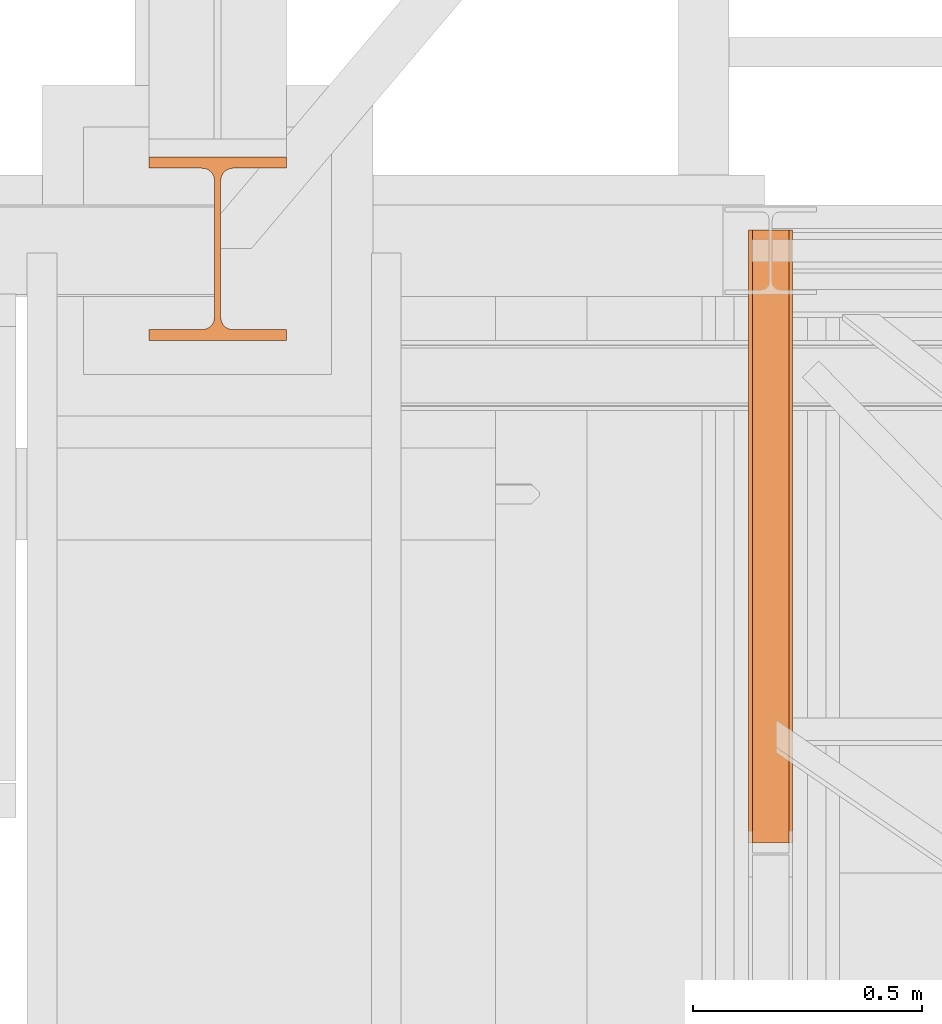
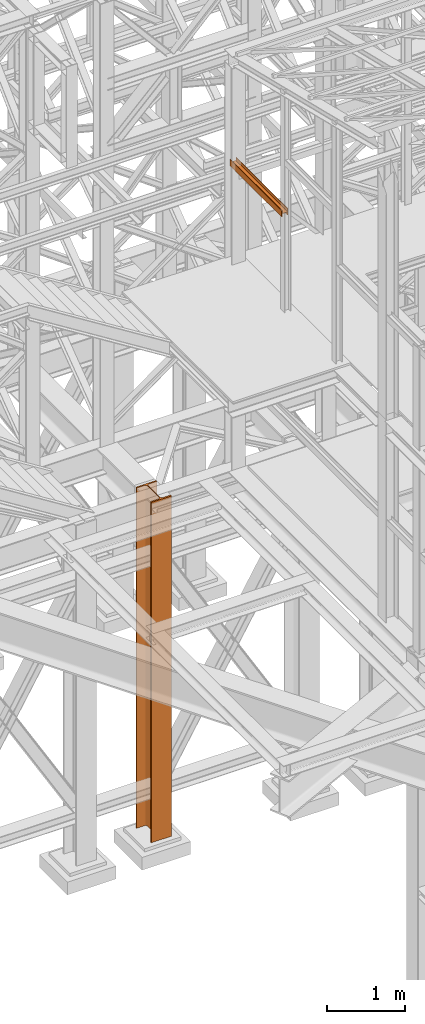
# One storey, part 31 of 208: 3 proxies.
"""IFC2X3 building model written with IfcOpenShell, lengths in millimetres."""

from ifc_helpers import new_model, entity, si_unit, converted_unit, frame, origin, origin_with_axes, place, context, subcontext, project, spatial, faceted_brep, element, save


model = new_model("IFC2X3")

# Units and contexts
model_context = context("Model", 3, precision=1e-05, world=origin())
plan_context = context("Plan", 3, precision=1e-05, world=origin())
body_context = subcontext(model_context, "Body", "Model", "MODEL_VIEW")
ifc_project = project(units=[si_unit("LENGTHUNIT", "METRE", prefix="MILLI"), converted_unit("PLANEANGLEUNIT", "DEGREE", entity("IfcPlaneAngleMeasure", 0.0174532925199433), si_unit("PLANEANGLEUNIT", "RADIAN"), dimensions=[0, 0, 0, 0, 0, 0, 0]), si_unit("AREAUNIT", "SQUARE_METRE"), si_unit("VOLUMEUNIT", "CUBIC_METRE")], contexts=[model_context, plan_context])

# Building, storey
building_placement = place(None, origin())
building = spatial("IfcBuilding", under=ifc_project, at=building_placement, CompositionType="COMPLEX")
storey_placement = place(building_placement, origin_with_axes())
storey = spatial("IfcBuildingStorey", under=building, at=storey_placement, Name="Geschoss", CompositionType="ELEMENT")

# Proxies
proxy_1_placement = place(storey_placement, frame((1150.254968528656, -18552.57438994535, 9977.249663113742), z_axis=(0.0, 0.0, 1.0), x_axis=(1.0, 0.0, 0.0)))
element("IfcBuildingElementProxy", 1, at=proxy_1_placement, inside=storey, context=body_context, shape_type="Brep", body=[
    faceted_brep([(8.009999999999991, 0.00999999999839929, 0.01000000000021828), (0.009999999999990905, 0.00999999999839929, 0.01000000000021828), (0.009999999999990905, 0.00999999999839929, 100.0100000000002), (8.009999999999991, 0.00999999999839929, 100.0100000000002), (8.009999999999991, 0.00999999999839929, 52.51000000000022), (88.00999999999999, 0.00999999999839929, 52.51000000000022), (88.00999999999999, 0.00999999999839929, 100.0100000000002), (96.00999999999999, 0.00999999999839929, 100.0100000000002), (96.00999999999999, 0.00999999999839929, 0.01000000000021828), (88.00999999999999, 0.00999999999839929, 0.01000000000021828), (88.00999999999999, 0.00999999999839929, 47.51000000000022), (8.009999999999991, 0.00999999999839929, 47.51000000000022), (0.009999999999990905, 0.00999999999839929, 0.01000000000021828), (8.009999999999991, 0.00999999999839929, 0.01000000000021828), (8.009999999999991, 1334.847202244597, 0.01000684652535711), (0.009999999999990905, 1334.847202244597, 0.01000684652535711), (0.009999999999990905, 0.00999999999839929, 100.0100000000002), (0.009999999999990905, 0.00999999999839929, 0.01000000000021828), (0.009999999999990905, 1334.847202244597, 0.01000684652535711), (0.009999999999990905, 1334.847202244597, 100.0100068465254), (8.009999999999991, 0.00999999999839929, 100.0100000000002), (0.009999999999990905, 0.00999999999839929, 100.0100000000002), (0.009999999999990905, 1334.847202244597, 100.0100068465254), (8.009999999999991, 1334.847202244597, 100.0100068465254), (8.009999999999991, 0.00999999999839929, 52.51000000000022), (8.009999999999991, 0.00999999999839929, 100.0100000000002), (8.009999999999991, 1334.847202244597, 100.0100068465254), (8.009999999999991, 1334.847202244597, 52.51000684652536), (88.00999999999999, 0.00999999999839929, 52.51000000000022), (8.009999999999991, 0.00999999999839929, 52.51000000000022), (8.009999999999991, 1334.847202244597, 52.51000684652536), (88.00999999999999, 1334.847202244597, 52.51000684652536), (88.00999999999999, 0.00999999999839929, 100.0100000000002), (88.00999999999999, 0.00999999999839929, 52.51000000000022), (88.00999999999999, 1334.847202244597, 52.51000684652536), (88.00999999999999, 1334.847202244597, 100.0100068465254), (96.00999999999999, 0.00999999999839929, 100.0100000000002), (88.00999999999999, 0.00999999999839929, 100.0100000000002), (88.00999999999999, 1334.847202244597, 100.0100068465254), (96.00999999999999, 1334.847202244597, 100.0100068465254), (96.00999999999999, 0.00999999999839929, 0.01000000000021828), (96.00999999999999, 0.00999999999839929, 100.0100000000002), (96.00999999999999, 1334.847202244597, 100.0100068465254), (96.00999999999999, 1334.847202244597, 0.01000684652535711), (88.00999999999999, 0.00999999999839929, 0.01000000000021828), (96.00999999999999, 0.00999999999839929, 0.01000000000021828), (96.00999999999999, 1334.847202244597, 0.01000684652535711), (88.00999999999999, 1334.847202244597, 0.01000684652535711), (88.00999999999999, 0.00999999999839929, 47.51000000000022), (88.00999999999999, 0.00999999999839929, 0.01000000000021828), (88.00999999999999, 1334.847202244597, 0.01000684652535711), (88.00999999999999, 1334.847202244597, 47.51000684652536), (8.009999999999991, 0.00999999999839929, 47.51000000000022), (88.00999999999999, 0.00999999999839929, 47.51000000000022), (88.00999999999999, 1334.847202244597, 47.51000684652536), (8.009999999999991, 1334.847202244597, 47.51000684652536), (8.009999999999991, 0.00999999999839929, 0.01000000000021828), (8.009999999999991, 0.00999999999839929, 47.51000000000022), (8.009999999999991, 1334.847202244597, 47.51000684652536), (8.009999999999991, 1334.847202244597, 0.01000684652535711), (8.009999999999991, 1334.847202244597, 0.01000684652535711), (8.009999999999991, 1334.847202244597, 47.51000684652536), (88.00999999999999, 1334.847202244597, 47.51000684652536), (88.00999999999999, 1334.847202244597, 0.01000684652535711), (96.00999999999999, 1334.847202244597, 0.01000684652535711), (96.00999999999999, 1334.847202244597, 100.0100068465254), (88.00999999999999, 1334.847202244597, 100.0100068465254), (88.00999999999999, 1334.847202244597, 52.51000684652536), (8.009999999999991, 1334.847202244597, 52.51000684652536), (8.009999999999991, 1334.847202244597, 100.0100068465254), (0.009999999999990905, 1334.847202244597, 100.0100068465254), (0.009999999999990905, 1334.847202244597, 0.01000684652535711)], [[[0, 1, 2, 3, 4, 5, 6, 7, 8, 9, 10, 11]], [[12, 13, 14, 15]], [[16, 17, 18, 19]], [[20, 21, 22, 23]], [[24, 25, 26, 27]], [[28, 29, 30, 31]], [[32, 33, 34, 35]], [[36, 37, 38, 39]], [[40, 41, 42, 43]], [[44, 45, 46, 47]], [[48, 49, 50, 51]], [[52, 53, 54, 55]], [[56, 57, 58, 59]], [[60, 61, 62, 63, 64, 65, 66, 67, 68, 69, 70, 71]]], orient=[[False], [False], [False], [False], [False], [False], [False], [False], [False], [False], [False], [False], [False], [False]]),
])
proxy_2_placement = place(storey_placement, frame((1150.254968528656, -18552.57438994535, 9977.249663113742), z_axis=(0.0, 0.0, 1.0), x_axis=(1.0, 0.0, 0.0)))
element("IfcBuildingElementProxy", 2, at=proxy_2_placement, inside=storey, context=body_context, shape_type="Brep", body=[
    faceted_brep([(8.009999999999991, 0.00999999999839929, 0.01000000000021828), (0.009999999999990905, 0.00999999999839929, 0.01000000000021828), (0.009999999999990905, 0.00999999999839929, 100.0100000000002), (8.009999999999991, 0.00999999999839929, 100.0100000000002), (8.009999999999991, 0.00999999999839929, 52.51000000000022), (88.00999999999999, 0.00999999999839929, 52.51000000000022), (88.00999999999999, 0.00999999999839929, 100.0100000000002), (96.00999999999999, 0.00999999999839929, 100.0100000000002), (96.00999999999999, 0.00999999999839929, 0.01000000000021828), (88.00999999999999, 0.00999999999839929, 0.01000000000021828), (88.00999999999999, 0.00999999999839929, 47.51000000000022), (8.009999999999991, 0.00999999999839929, 47.51000000000022), (0.009999999999990905, 0.00999999999839929, 0.01000000000021828), (8.009999999999991, 0.00999999999839929, 0.01000000000021828), (8.009999999999991, 1334.847202244597, 0.01000684652535711), (0.009999999999990905, 1334.847202244597, 0.01000684652535711), (0.009999999999990905, 0.00999999999839929, 100.0100000000002), (0.009999999999990905, 0.00999999999839929, 0.01000000000021828), (0.009999999999990905, 1334.847202244597, 0.01000684652535711), (0.009999999999990905, 1334.847202244597, 100.0100068465254), (8.009999999999991, 0.00999999999839929, 100.0100000000002), (0.009999999999990905, 0.00999999999839929, 100.0100000000002), (0.009999999999990905, 1334.847202244597, 100.0100068465254), (8.009999999999991, 1334.847202244597, 100.0100068465254), (8.009999999999991, 0.00999999999839929, 52.51000000000022), (8.009999999999991, 0.00999999999839929, 100.0100000000002), (8.009999999999991, 1334.847202244597, 100.0100068465254), (8.009999999999991, 1334.847202244597, 52.51000684652536), (88.00999999999999, 0.00999999999839929, 52.51000000000022), (8.009999999999991, 0.00999999999839929, 52.51000000000022), (8.009999999999991, 1334.847202244597, 52.51000684652536), (88.00999999999999, 1334.847202244597, 52.51000684652536), (88.00999999999999, 0.00999999999839929, 100.0100000000002), (88.00999999999999, 0.00999999999839929, 52.51000000000022), (88.00999999999999, 1334.847202244597, 52.51000684652536), (88.00999999999999, 1334.847202244597, 100.0100068465254), (96.00999999999999, 0.00999999999839929, 100.0100000000002), (88.00999999999999, 0.00999999999839929, 100.0100000000002), (88.00999999999999, 1334.847202244597, 100.0100068465254), (96.00999999999999, 1334.847202244597, 100.0100068465254), (96.00999999999999, 0.00999999999839929, 0.01000000000021828), (96.00999999999999, 0.00999999999839929, 100.0100000000002), (96.00999999999999, 1334.847202244597, 100.0100068465254), (96.00999999999999, 1334.847202244597, 0.01000684652535711), (88.00999999999999, 0.00999999999839929, 0.01000000000021828), (96.00999999999999, 0.00999999999839929, 0.01000000000021828), (96.00999999999999, 1334.847202244597, 0.01000684652535711), (88.00999999999999, 1334.847202244597, 0.01000684652535711), (88.00999999999999, 0.00999999999839929, 47.51000000000022), (88.00999999999999, 0.00999999999839929, 0.01000000000021828), (88.00999999999999, 1334.847202244597, 0.01000684652535711), (88.00999999999999, 1334.847202244597, 47.51000684652536), (8.009999999999991, 0.00999999999839929, 47.51000000000022), (88.00999999999999, 0.00999999999839929, 47.51000000000022), (88.00999999999999, 1334.847202244597, 47.51000684652536), (8.009999999999991, 1334.847202244597, 47.51000684652536), (8.009999999999991, 0.00999999999839929, 0.01000000000021828), (8.009999999999991, 0.00999999999839929, 47.51000000000022), (8.009999999999991, 1334.847202244597, 47.51000684652536), (8.009999999999991, 1334.847202244597, 0.01000684652535711), (8.009999999999991, 1334.847202244597, 0.01000684652535711), (8.009999999999991, 1334.847202244597, 47.51000684652536), (88.00999999999999, 1334.847202244597, 47.51000684652536), (88.00999999999999, 1334.847202244597, 0.01000684652535711), (96.00999999999999, 1334.847202244597, 0.01000684652535711), (96.00999999999999, 1334.847202244597, 100.0100068465254), (88.00999999999999, 1334.847202244597, 100.0100068465254), (88.00999999999999, 1334.847202244597, 52.51000684652536), (8.009999999999991, 1334.847202244597, 52.51000684652536), (8.009999999999991, 1334.847202244597, 100.0100068465254), (0.009999999999990905, 1334.847202244597, 100.0100068465254), (0.009999999999990905, 1334.847202244597, 0.01000684652535711)], [[[0, 1, 2, 3, 4, 5, 6, 7, 8, 9, 10, 11]], [[12, 13, 14, 15]], [[16, 17, 18, 19]], [[20, 21, 22, 23]], [[24, 25, 26, 27]], [[28, 29, 30, 31]], [[32, 33, 34, 35]], [[36, 37, 38, 39]], [[40, 41, 42, 43]], [[44, 45, 46, 47]], [[48, 49, 50, 51]], [[52, 53, 54, 55]], [[56, 57, 58, 59]], [[60, 61, 62, 63, 64, 65, 66, 67, 68, 69, 70, 71]]], orient=[[False], [False], [False], [False], [False], [False], [False], [False], [False], [False], [False], [False], [False], [False]]),
])
proxy_3_placement = place(storey_placement, frame((-156.7450314713294, -17458.57439531565, -65.01000000000022), z_axis=(0.0, 0.0, 1.0), x_axis=(1.0, 0.0, 0.0)))
element("IfcBuildingElementProxy", 3, at=proxy_3_placement, inside=storey, Name="3D Element", context=body_context, shape_type="Brep", body=[
    faceted_brep([(0.009999999999990905, 400.0099999999984, 5350.010005364416), (300.01, 400.0099999999984, 5350.010005364416), (300.01, 376.0099999999984, 5350.010005364416), (183.76, 376.0099999999984, 5350.010005364416), (175.4165694541391, 374.6884339422577, 5350.010005364416), (167.8898249341985, 370.8534254633996, 5350.010005364416), (161.9165745365979, 364.8801750657985, 5350.010005364416), (157.9269689743871, 356.3774142355105, 5350.010005364416), (156.76, 349.0099999999984, 5350.010005364416), (156.76, 51.0099999999984, 5350.010005364416), (158.0815660577403, 42.66656945413706, 5350.010005364416), (161.9165745365979, 35.13982493419462, 5350.010005364416), (167.8898249341985, 29.16657453659718, 5350.010005364416), (175.4165694541391, 25.33156605773911, 5350.010005364416), (183.76, 24.0099999999984, 5350.010005364416), (300.01, 24.0099999999984, 5350.010005364416), (300.01, 0.00999999999839929, 5350.010005364416), (0.009999999999990905, 0.00999999999839929, 5350.010005364416), (0.009999999999990905, 24.0099999999984, 5350.010005364416), (116.26, 24.0099999999984, 5350.010005364416), (124.6034305458604, 25.33156605773911, 5350.010005364416), (132.1301750658015, 29.16657453659718, 5350.010005364416), (138.1034254634017, 35.13982493419462, 5350.010005364416), (141.9384339422597, 42.66656945413706, 5350.010005364416), (143.26, 51.0099999999984, 5350.010005364416), (143.26, 347.9786887785667, 5350.010005364416), (141.9384339422597, 357.3534305458597, 5350.010005364416), (138.1034254634021, 364.8801750657985, 5350.010005364416), (132.1301750658015, 370.8534254633996, 5350.010005364416), (124.6034305458604, 374.6884339422577, 5350.010005364416), (115.0308095164803, 376.0099999999984, 5350.010005364416), (0.009999999999990905, 376.0099999999984, 5350.010005364416), (300.01, 400.0099999999984, 5350.010005364416), (0.009999999999990905, 400.0099999999984, 5350.010005364416), (0.009999999999990905, 400.0099999999984, 0.01000000000021828), (300.01, 400.0099999999984, 0.01000000000021828), (300.01, 376.0099999999984, 5350.010005364416), (300.01, 400.0099999999984, 5350.010005364416), (300.01, 400.0099999999984, 0.01000000000021828), (300.01, 376.0099999999984, 0.01000000000021828), (183.76, 376.0099999999984, 5350.010005364416), (300.01, 376.0099999999984, 5350.010005364416), (300.01, 376.0099999999984, 0.01000000000021828), (183.76, 376.0099999999984, 0.01000000000021828), (175.4165694541391, 374.6884339422577, 5350.010005364416), (183.76, 376.0099999999984, 5350.010005364416), (183.76, 376.0099999999984, 0.01000000000021828), (175.4165694541391, 374.6884339422577, 0.01000000000021828), (167.8898249341985, 370.8534254633996, 5350.010005364416), (175.4165694541391, 374.6884339422577, 5350.010005364416), (175.4165694541391, 374.6884339422577, 0.01000000000021828), (167.8898249341985, 370.8534254633996, 0.01000000000021828), (161.9165745365979, 364.8801750657985, 5350.010005364416), (167.8898249341985, 370.8534254633996, 5350.010005364416), (167.8898249341985, 370.8534254633996, 0.01000000000021828), (161.9165745365979, 364.8801750657985, 0.01000000000021828), (157.9269689743871, 356.3774142355105, 5350.010005364416), (161.9165745365979, 364.8801750657985, 5350.010005364416), (161.9165745365979, 364.8801750657985, 0.01000000000021828), (157.9269689743871, 356.3774142355105, 0.01000000000021828), (156.76, 349.0099999999984, 5350.010005364416), (157.9269689743871, 356.3774142355105, 5350.010005364416), (157.9269689743871, 356.3774142355105, 0.01000000000021828), (156.76, 349.0099999999984, 0.01000000000021828), (156.76, 51.0099999999984, 5350.010005364416), (156.76, 349.0099999999984, 5350.010005364416), (156.76, 349.0099999999984, 0.01000000000021828), (156.76, 51.0099999999984, 0.01000000000021828), (158.0815660577403, 42.66656945413706, 5350.010005364416), (156.76, 51.0099999999984, 5350.010005364416), (156.76, 51.0099999999984, 0.01000000000021828), (158.0815660577403, 42.66656945413706, 0.01000000000021828), (161.9165745365979, 35.13982493419462, 5350.010005364416), (158.0815660577403, 42.66656945413706, 5350.010005364416), (158.0815660577403, 42.66656945413706, 0.01000000000021828), (161.9165745365979, 35.13982493419462, 0.01000000000021828), (167.8898249341985, 29.16657453659718, 5350.010005364416), (161.9165745365979, 35.13982493419462, 5350.010005364416), (161.9165745365979, 35.13982493419462, 0.01000000000021828), (167.8898249341985, 29.16657453659718, 0.01000000000021828), (175.4165694541391, 25.33156605773911, 5350.010005364416), (167.8898249341985, 29.16657453659718, 5350.010005364416), (167.8898249341985, 29.16657453659718, 0.01000000000021828), (175.4165694541391, 25.33156605773911, 0.01000000000021828), (183.76, 24.0099999999984, 5350.010005364416), (175.4165694541391, 25.33156605773911, 5350.010005364416), (175.4165694541391, 25.33156605773911, 0.01000000000021828), (183.76, 24.0099999999984, 0.01000000000021828), (300.01, 24.0099999999984, 5350.010005364416), (183.76, 24.0099999999984, 5350.010005364416), (183.76, 24.0099999999984, 0.01000000000021828), (300.01, 24.0099999999984, 0.01000000000021828), (300.01, 0.00999999999839929, 5350.010005364416), (300.01, 24.0099999999984, 5350.010005364416), (300.01, 24.0099999999984, 0.01000000000021828), (300.01, 0.00999999999839929, 0.01000000000021828), (0.009999999999990905, 0.00999999999839929, 5350.010005364416), (300.01, 0.00999999999839929, 5350.010005364416), (300.01, 0.00999999999839929, 0.01000000000021828), (0.009999999999990905, 0.00999999999839929, 0.01000000000021828), (0.009999999999990905, 24.0099999999984, 5350.010005364416), (0.009999999999990905, 0.00999999999839929, 5350.010005364416), (0.009999999999990905, 0.00999999999839929, 0.01000000000021828), (0.009999999999990905, 24.0099999999984, 0.01000000000021828), (116.26, 24.0099999999984, 5350.010005364416), (0.009999999999990905, 24.0099999999984, 5350.010005364416), (0.009999999999990905, 24.0099999999984, 0.01000000000021828), (116.26, 24.0099999999984, 0.01000000000021828), (124.6034305458604, 25.33156605773911, 5350.010005364416), (116.26, 24.0099999999984, 5350.010005364416), (116.26, 24.0099999999984, 0.01000000000021828), (124.6034305458604, 25.33156605773911, 0.01000000000021828), (132.1301750658015, 29.16657453659718, 5350.010005364416), (124.6034305458604, 25.33156605773911, 5350.010005364416), (124.6034305458604, 25.33156605773911, 0.01000000000021828), (132.1301750658015, 29.16657453659718, 0.01000000000021828), (138.1034254634017, 35.13982493419462, 5350.010005364416), (132.1301750658015, 29.16657453659718, 5350.010005364416), (132.1301750658015, 29.16657453659718, 0.01000000000021828), (138.1034254634017, 35.13982493419462, 0.01000000000021828), (141.9384339422597, 42.66656945413706, 5350.010005364416), (138.1034254634017, 35.13982493419462, 5350.010005364416), (138.1034254634017, 35.13982493419462, 0.01000000000021828), (141.9384339422597, 42.66656945413706, 0.01000000000021828), (143.26, 51.0099999999984, 5350.010005364416), (141.9384339422597, 42.66656945413706, 5350.010005364416), (141.9384339422597, 42.66656945413706, 0.01000000000021828), (143.26, 51.0099999999984, 0.01000000000021828), (143.26, 347.9786887785667, 5350.010005364416), (143.26, 51.0099999999984, 5350.010005364416), (143.26, 51.0099999999984, 0.01000000000021828), (143.26, 347.9786887785667, 0.01000000000021828), (141.9384339422597, 357.3534305458597, 5350.010005364416), (143.26, 347.9786887785667, 5350.010005364416), (143.26, 347.9786887785667, 0.01000000000021828), (141.9384339422597, 357.3534305458597, 0.01000000000021828), (138.1034254634021, 364.8801750657985, 5350.010005364416), (141.9384339422597, 357.3534305458597, 5350.010005364416), (141.9384339422597, 357.3534305458597, 0.01000000000021828), (138.1034254634021, 364.8801750657985, 0.01000000000021828), (132.1301750658015, 370.8534254633996, 5350.010005364416), (138.1034254634021, 364.8801750657985, 5350.010005364416), (138.1034254634021, 364.8801750657985, 0.01000000000021828), (132.1301750658015, 370.8534254633996, 0.01000000000021828), (124.6034305458604, 374.6884339422577, 5350.010005364416), (132.1301750658015, 370.8534254633996, 5350.010005364416), (132.1301750658015, 370.8534254633996, 0.01000000000021828), (124.6034305458604, 374.6884339422577, 0.01000000000021828), (115.0308095164803, 376.0099999999984, 5350.010005364416), (124.6034305458604, 374.6884339422577, 5350.010005364416), (124.6034305458604, 374.6884339422577, 0.01000000000021828), (115.0308095164803, 376.0099999999984, 0.01000000000021828), (0.009999999999990905, 376.0099999999984, 5350.010005364416), (115.0308095164803, 376.0099999999984, 5350.010005364416), (115.0308095164803, 376.0099999999984, 0.01000000000021828), (0.009999999999990905, 376.0099999999984, 0.01000000000021828), (0.009999999999990905, 400.0099999999984, 5350.010005364416), (0.009999999999990905, 376.0099999999984, 5350.010005364416), (0.009999999999990905, 376.0099999999984, 0.01000000000021828), (0.009999999999990905, 400.0099999999984, 0.01000000000021828), (0.009999999999990905, 400.0099999999984, 0.01000000000021828), (0.009999999999990905, 376.0099999999984, 0.01000000000021828), (115.0308095164803, 376.0099999999984, 0.01000000000021828), (124.6034305458604, 374.6884339422577, 0.01000000000021828), (132.1301750658015, 370.8534254633996, 0.01000000000021828), (138.1034254634021, 364.8801750657985, 0.01000000000021828), (141.9384339422597, 357.3534305458597, 0.01000000000021828), (143.26, 347.9786887785667, 0.01000000000021828), (143.26, 51.0099999999984, 0.01000000000021828), (141.9384339422597, 42.66656945413706, 0.01000000000021828), (138.1034254634017, 35.13982493419462, 0.01000000000021828), (132.1301750658015, 29.16657453659718, 0.01000000000021828), (124.6034305458604, 25.33156605773911, 0.01000000000021828), (116.26, 24.0099999999984, 0.01000000000021828), (0.009999999999990905, 24.0099999999984, 0.01000000000021828), (0.009999999999990905, 0.00999999999839929, 0.01000000000021828), (300.01, 0.00999999999839929, 0.01000000000021828), (300.01, 24.0099999999984, 0.01000000000021828), (183.76, 24.0099999999984, 0.01000000000021828), (175.4165694541391, 25.33156605773911, 0.01000000000021828), (167.8898249341985, 29.16657453659718, 0.01000000000021828), (161.9165745365979, 35.13982493419462, 0.01000000000021828), (158.0815660577403, 42.66656945413706, 0.01000000000021828), (156.76, 51.0099999999984, 0.01000000000021828), (156.76, 349.0099999999984, 0.01000000000021828), (157.9269689743871, 356.3774142355105, 0.01000000000021828), (161.9165745365979, 364.8801750657985, 0.01000000000021828), (167.8898249341985, 370.8534254633996, 0.01000000000021828), (175.4165694541391, 374.6884339422577, 0.01000000000021828), (183.76, 376.0099999999984, 0.01000000000021828), (300.01, 376.0099999999984, 0.01000000000021828), (300.01, 400.0099999999984, 0.01000000000021828)], [[[0, 1, 2, 3, 4, 5, 6, 7, 8, 9, 10, 11, 12, 13, 14, 15, 16, 17, 18, 19, 20, 21, 22, 23, 24, 25, 26, 27, 28, 29, 30, 31]], [[32, 33, 34, 35]], [[36, 37, 38, 39]], [[40, 41, 42, 43]], [[44, 45, 46, 47]], [[48, 49, 50, 51]], [[52, 53, 54, 55]], [[56, 57, 58, 59]], [[60, 61, 62, 63]], [[64, 65, 66, 67]], [[68, 69, 70, 71]], [[72, 73, 74, 75]], [[76, 77, 78, 79]], [[80, 81, 82, 83]], [[84, 85, 86, 87]], [[88, 89, 90, 91]], [[92, 93, 94, 95]], [[96, 97, 98, 99]], [[100, 101, 102, 103]], [[104, 105, 106, 107]], [[108, 109, 110, 111]], [[112, 113, 114, 115]], [[116, 117, 118, 119]], [[120, 121, 122, 123]], [[124, 125, 126, 127]], [[128, 129, 130, 131]], [[132, 133, 134, 135]], [[136, 137, 138, 139]], [[140, 141, 142, 143]], [[144, 145, 146, 147]], [[148, 149, 150, 151]], [[152, 153, 154, 155]], [[156, 157, 158, 159]], [[160, 161, 162, 163, 164, 165, 166, 167, 168, 169, 170, 171, 172, 173, 174, 175, 176, 177, 178, 179, 180, 181, 182, 183, 184, 185, 186, 187, 188, 189, 190, 191]]], orient=[[False], [False], [False], [False], [False], [False], [False], [False], [False], [False], [False], [False], [False], [False], [False], [False], [False], [False], [False], [False], [False], [False], [False], [False], [False], [False], [False], [False], [False], [False], [False], [False], [False], [False]]),
])

save(model, "model.ifc")
